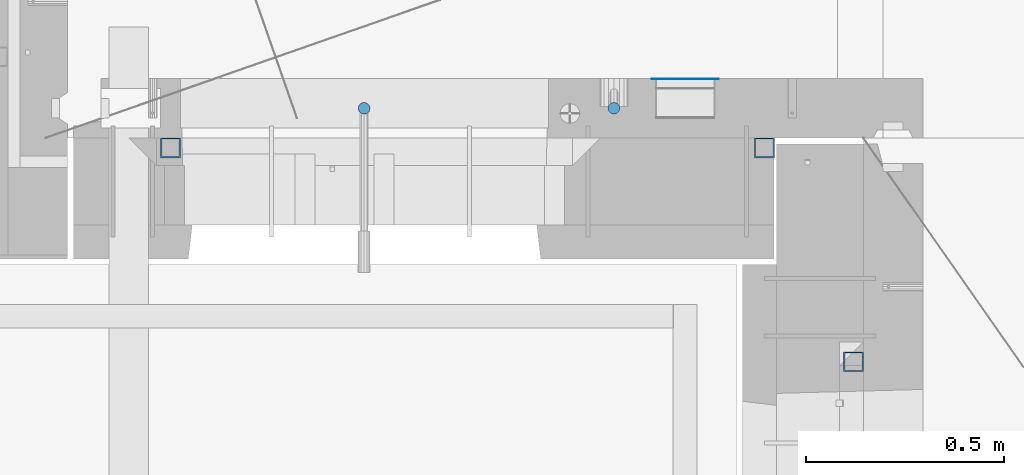
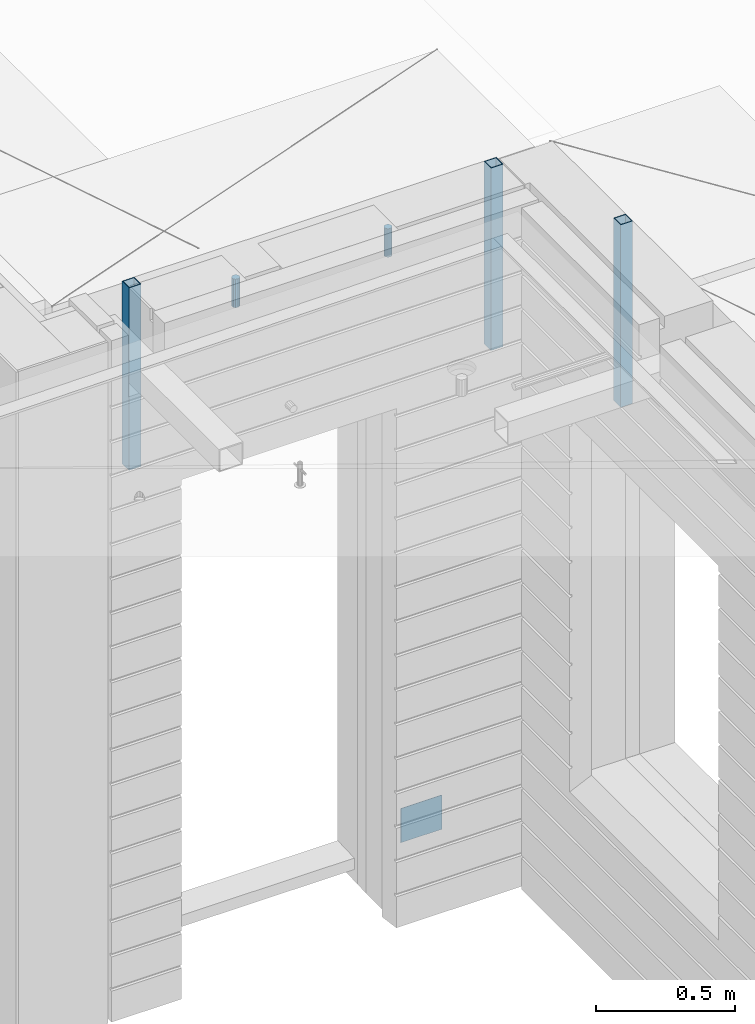
# One storey, part 12 of 352: 6 columns, 6 elements without a shape of their own.
"""IFC2X3 building model written with IfcOpenShell, lengths in millimetres."""

from ifc_helpers import new_model, si_unit, frame, origin_with_axes, place, context, subcontext, project, spatial, faceted_brep, material, type_object, element, aggregate, save


model = new_model("IFC2X3")

# Units and contexts
model_context = context("Model", 3, precision=1e-05, world=origin_with_axes())
body_context = subcontext(model_context, "Body", "Model", "MODEL_VIEW")
ifc_project = project(units=[si_unit("LENGTHUNIT", "METRE", prefix="MILLI"), si_unit("AREAUNIT", "SQUARE_METRE"), si_unit("VOLUMEUNIT", "CUBIC_METRE"), si_unit("MASSUNIT", "GRAM", prefix="KILO"), si_unit("TIMEUNIT", "SECOND"), si_unit("PLANEANGLEUNIT", "RADIAN"), si_unit("SOLIDANGLEUNIT", "STERADIAN"), si_unit("THERMODYNAMICTEMPERATUREUNIT", "DEGREE_CELSIUS"), si_unit("LUMINOUSINTENSITYUNIT", "LUMEN")], contexts=[model_context])

# Site, building, storey
site_placement = place(None, origin_with_axes())
site = spatial("IfcSite", under=ifc_project, at=site_placement, CompositionType="ELEMENT")
building_placement = place(site_placement, origin_with_axes())
building = spatial("IfcBuilding", under=site, at=building_placement, CompositionType="ELEMENT")
storey_placement = place(building_placement, origin_with_axes())
storey = spatial("IfcBuildingStorey", under=building, at=storey_placement, Name="6", CompositionType="ELEMENT", Elevation=0.0)

# Assemblies, columns
assembly_1_placement = place(storey_placement, origin_with_axes())
assembly_1 = element("IfcElementAssembly", 1, at=assembly_1_placement, inside=storey, AssemblyPlace="NOTDEFINED", PredefinedType="REINFORCEMENT_UNIT")
ifc_material_1 = material()
column_type_1 = type_object("IfcColumnType", Name="D30", PredefinedType="NOTDEFINED")
column_1_placement = place(assembly_1_placement, frame((9379.99827996565, 11025.0, 99407.5), z_axis=(0.0, -1.0, 0.0), x_axis=(0.0, 0.0, 1.0)))
column_1 = element("IfcColumn", 2, at=column_1_placement, type_object=column_type_1, material=ifc_material_1, ObjectType="D30", context=body_context, shape_type="Brep", body=[
    faceted_brep([(0.0, -15.0, 0.0), (0.0, -12.9903810567666, -7.5), (125.0, -12.9903810567666, -7.5), (125.0, -15.0, 0.0), (0.0, -7.5, -12.9903810567666), (125.0, -7.5, -12.9903810567666), (0.0, 0.0, -15.0), (125.0, 0.0, -15.0), (0.0, 7.5, -12.9903810567666), (125.0, 7.5, -12.9903810567666), (0.0, 12.9903810567666, -7.5), (125.0, 12.9903810567666, -7.5), (0.0, 15.0, 0.0), (125.0, 15.0, 0.0), (0.0, 12.9903810567666, 7.5), (125.0, 12.9903810567666, 7.5), (0.0, 7.5, 12.9903810567666), (125.0, 7.5, 12.9903810567666), (0.0, 0.0, 15.0), (125.0, 0.0, 15.0), (0.0, -7.5, 12.9903810567666), (125.0, -7.5, 12.9903810567666), (0.0, -12.9903810567666, 7.5), (125.0, -12.9903810567666, 7.5)], [[[0, 1, 2, 3]], [[1, 4, 5, 2]], [[4, 6, 7, 5]], [[6, 8, 9, 7]], [[8, 10, 11, 9]], [[10, 12, 13, 11]], [[12, 14, 15, 13]], [[14, 16, 17, 15]], [[16, 18, 19, 17]], [[18, 20, 21, 19]], [[20, 22, 23, 21]], [[22, 0, 3, 23]], [[5, 7, 9, 11, 13, 15, 17, 19, 21, 23, 3, 2]], [[22, 20, 18, 16, 14, 12, 10, 8, 6, 4, 1, 0]]]),
])
column_2_placement = place(assembly_1_placement, frame((8748.99633326467, 11025.0000000071, 99407.5), z_axis=(0.0, 1.0, 0.0), x_axis=(0.0, 0.0, 1.0)))
column_2 = element("IfcColumn", 3, at=column_2_placement, type_object=column_type_1, material=ifc_material_1, ObjectType="D30", context=body_context, shape_type="Brep", body=[
    faceted_brep([(0.0, -15.0, 0.0), (0.0, -12.9903810567666, -7.5), (125.0, -12.9903810567666, -7.5), (125.0, -15.0, 0.0), (0.0, -7.5, -12.9903810567666), (125.0, -7.5, -12.9903810567666), (0.0, 0.0, -15.0), (125.0, 0.0, -15.0), (0.0, 7.5, -12.9903810567666), (125.0, 7.5, -12.9903810567666), (0.0, 12.9903810567666, -7.5), (125.0, 12.9903810567666, -7.5), (0.0, 15.0, 0.0), (125.0, 15.0, 0.0), (0.0, 12.9903810567666, 7.5), (125.0, 12.9903810567666, 7.5), (0.0, 7.5, 12.9903810567666), (125.0, 7.5, 12.9903810567666), (0.0, 0.0, 15.0), (125.0, 0.0, 15.0), (0.0, -7.5, 12.9903810567666), (125.0, -7.5, 12.9903810567666), (0.0, -12.9903810567666, 7.5), (125.0, -12.9903810567666, 7.5)], [[[0, 1, 2, 3]], [[1, 4, 5, 2]], [[4, 6, 7, 5]], [[6, 8, 9, 7]], [[8, 10, 11, 9]], [[10, 12, 13, 11]], [[12, 14, 15, 13]], [[14, 16, 17, 15]], [[16, 18, 19, 17]], [[18, 20, 21, 19]], [[20, 22, 23, 21]], [[22, 0, 3, 23]], [[5, 7, 9, 11, 13, 15, 17, 19, 21, 23, 3, 2]], [[22, 20, 18, 16, 14, 12, 10, 8, 6, 4, 1, 0]]]),
])
assembly_2_placement = place(assembly_1_placement, origin_with_axes())
assembly_2 = element("IfcElementAssembly", 4, at=assembly_2_placement, Name="Steel Assembly", AssemblyPlace="NOTDEFINED", PredefinedType="NOTDEFINED")
ifc_material_2 = material(Name="Undefined")
column_type_2 = type_object("IfcColumnType", PredefinedType="NOTDEFINED")
column_3_placement = place(assembly_2_placement, frame((9560.0000000031, 11098.9999999984, 96754.9999999985), z_axis=(0.0, 1.0, 0.0), x_axis=(0.0, 0.0, 1.0)))
column_3 = element("IfcColumn", 5, at=column_3_placement, type_object=column_type_2, material=ifc_material_2, Name="SPK2", context=body_context, shape_type="Brep", body=[
    faceted_brep([(0.0, 85.0, -1.0), (0.0, 85.0, 1.0), (150.0, 85.0, 1.0), (150.0, 85.0, -1.0), (0.0, -85.0, 1.0), (150.0, -85.0, 1.0), (0.0, -85.0, -1.0), (150.0, -85.0, -1.0)], [[[0, 1, 2, 3]], [[1, 4, 5, 2]], [[4, 6, 7, 5]], [[6, 0, 3, 7]], [[5, 7, 3, 2]], [[6, 4, 1, 0]]]),
])
aggregate(assembly_2, [column_3])

# Assemblies, column
assembly_3_placement = place(storey_placement, origin_with_axes())
assembly_3 = element("IfcElementAssembly", 6, at=assembly_3_placement, inside=storey, AssemblyPlace="NOTDEFINED", PredefinedType="REINFORCEMENT_UNIT")
assembly_4_placement = place(assembly_3_placement, origin_with_axes())
assembly_4 = element("IfcElementAssembly", 7, at=assembly_4_placement, Name="Steel Assembly", AssemblyPlace="NOTDEFINED", PredefinedType="RIGID_FRAME")
aggregate(assembly_3, [assembly_4])
ifc_material_3 = material(Name="STEEL/S355J2")
column_type_3 = type_object("IfcColumnType", Name="50X50X3", PredefinedType="NOTDEFINED")
column_4_placement = place(assembly_4_placement, frame((9985.0, 10385.0, 98940.0), z_axis=(0.0, 1.0, 0.0), x_axis=(0.0, 0.0, 1.0)))
column_4 = element("IfcColumn", 8, at=column_4_placement, type_object=column_type_3, material=ifc_material_3, ObjectType="50X50X3", context=body_context, shape_type="Brep", body=[
    faceted_brep([(0.0, 22.0, -22.0), (0.0, -22.0, -22.0), (800.0, -22.0, -22.0), (800.0, 22.0, -22.0), (0.0, -22.0, 22.0), (800.0, -22.0, 22.0), (0.0, 22.0, 22.0), (800.0, 22.0, 22.0), (0.0, 25.0, -25.0), (0.0, 25.0, 25.0), (800.0, 25.0, 25.0), (800.0, 25.0, -25.0), (0.0, -25.0, 25.0), (800.0, -25.0, 25.0), (0.0, -25.0, -25.0), (800.0, -25.0, -25.0)], [[[0, 1, 2, 3]], [[1, 4, 5, 2]], [[4, 6, 7, 5]], [[6, 0, 3, 7]], [[8, 9, 10, 11]], [[9, 12, 13, 10]], [[12, 14, 15, 13]], [[14, 8, 11, 15]], [[13, 15, 11, 10], [5, 7, 3, 2]], [[14, 12, 9, 8], [6, 4, 1, 0]]]),
])
aggregate(assembly_4, [column_4])

# Assembly, column
assembly_5_placement = place(assembly_1_placement, origin_with_axes())
assembly_5 = element("IfcElementAssembly", 9, at=assembly_5_placement, Name="Steel Assembly", AssemblyPlace="NOTDEFINED", PredefinedType="RIGID_FRAME")
column_5_placement = place(assembly_5_placement, frame((8260.0, 10925.0, 98940.0), z_axis=(1.0, 0.0, 0.0), x_axis=(0.0, 0.0, 1.0)))
column_5 = element("IfcColumn", 10, at=column_5_placement, type_object=column_type_3, material=ifc_material_3, ObjectType="50X50X3", context=body_context, shape_type="Brep", body=[
    faceted_brep([(0.0, 22.0, -22.0), (0.0, -22.0, -22.0), (800.0, -22.0, -22.0), (800.0, 22.0, -22.0), (0.0, -22.0, 22.0), (800.0, -22.0, 22.0), (0.0, 22.0, 22.0), (800.0, 22.0, 22.0), (0.0, 25.0, -25.0), (0.0, 25.0, 25.0), (800.0, 25.0, 25.0), (800.0, 25.0, -25.0), (0.0, -25.0, 25.0), (800.0, -25.0, 25.0), (0.0, -25.0, -25.0), (800.0, -25.0, -25.0)], [[[0, 1, 2, 3]], [[1, 4, 5, 2]], [[4, 6, 7, 5]], [[6, 0, 3, 7]], [[8, 9, 10, 11]], [[9, 12, 13, 10]], [[12, 14, 15, 13]], [[14, 8, 11, 15]], [[13, 15, 11, 10], [5, 7, 3, 2]], [[14, 12, 9, 8], [6, 4, 1, 0]]]),
])
aggregate(assembly_5, [column_5])

# Assembly
assembly_6_placement = place(assembly_1_placement, origin_with_axes())
assembly_6 = element("IfcElementAssembly", 11, at=assembly_6_placement, Name="Steel Assembly", AssemblyPlace="NOTDEFINED", PredefinedType="RIGID_FRAME")

aggregate(assembly_1, [column_1, column_2, assembly_2, assembly_5, assembly_6])

# Column
column_6_placement = place(assembly_6_placement, frame((9760.0, 10925.0, 98940.0), z_axis=(1.0, 0.0, 0.0), x_axis=(0.0, 0.0, 1.0)))
column_6 = element("IfcColumn", 12, at=column_6_placement, type_object=column_type_3, material=ifc_material_3, ObjectType="50X50X3", context=body_context, shape_type="Brep", body=[
    faceted_brep([(0.0, 22.0, -22.0), (0.0, -22.0, -22.0), (800.0, -22.0, -22.0), (800.0, 22.0, -22.0), (0.0, -22.0, 22.0), (800.0, -22.0, 22.0), (0.0, 22.0, 22.0), (800.0, 22.0, 22.0), (0.0, 25.0, -25.0), (0.0, 25.0, 25.0), (800.0, 25.0, 25.0), (800.0, 25.0, -25.0), (0.0, -25.0, 25.0), (800.0, -25.0, 25.0), (0.0, -25.0, -25.0), (800.0, -25.0, -25.0)], [[[0, 1, 2, 3]], [[1, 4, 5, 2]], [[4, 6, 7, 5]], [[6, 0, 3, 7]], [[8, 9, 10, 11]], [[9, 12, 13, 10]], [[12, 14, 15, 13]], [[14, 8, 11, 15]], [[13, 15, 11, 10], [5, 7, 3, 2]], [[14, 12, 9, 8], [6, 4, 1, 0]]]),
])

aggregate(assembly_6, [column_6])

save(model, "model.ifc")
